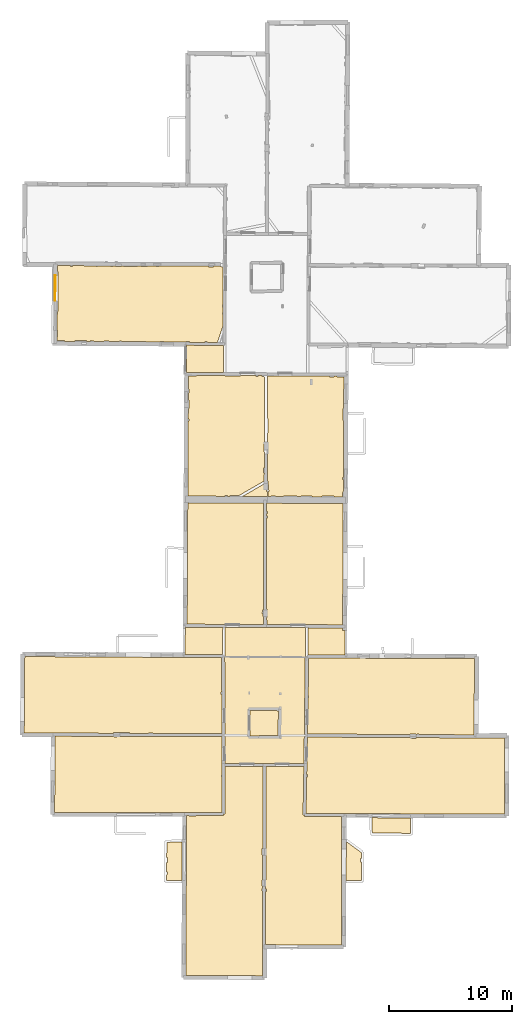
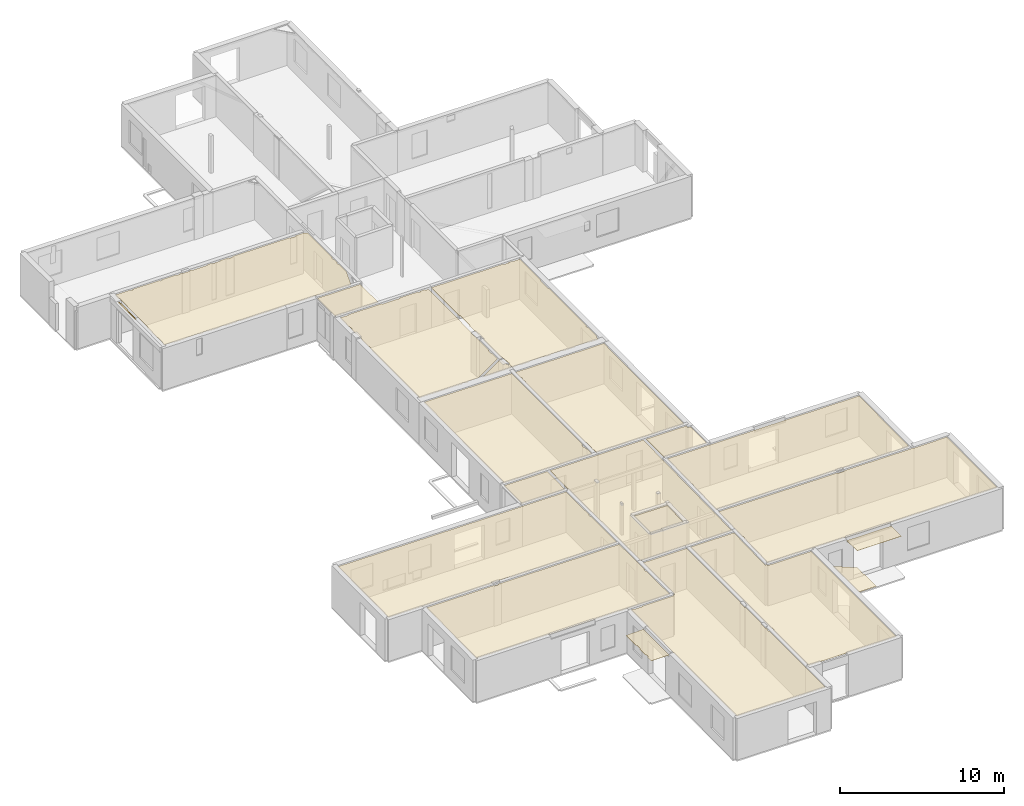
# One storey, part 14 of 17: 21 coverings.
"""IFC2X3 building model written with IfcOpenShell, lengths in metres."""

from ifc_helpers import new_model, entity, si_unit, converted_unit, derived_unit, direction, frame, origin, origin_with_axes, place, context, subcontext, project, spatial, polyline, outline, extrude, material, layer, layer_set, layer_usage, type_object, element, save


model = new_model("IFC2X3")

# Units and contexts
model_context = context("Model", 3, precision=1e-05, world=origin(), true_north=direction((0.0, 1.0)))
body_context = subcontext(model_context, "Body", "Model", "MODEL_VIEW")
ifc_project = project(units=[si_unit("LENGTHUNIT", "METRE"), si_unit("AREAUNIT", "SQUARE_METRE"), si_unit("VOLUMEUNIT", "CUBIC_METRE"), converted_unit("PLANEANGLEUNIT", "DEGREE", entity("IfcRatioMeasure", 0.0174532925199433), si_unit("PLANEANGLEUNIT", "RADIAN"), dimensions=[0, 0, 0, 0, 0, 0, 0]), si_unit("MASSUNIT", "GRAM", prefix="KILO"), derived_unit("MASSDENSITYUNIT", [(si_unit("MASSUNIT", "GRAM", prefix="KILO"), 1), (si_unit("LENGTHUNIT", "METRE"), -3)]), derived_unit("MOMENTOFINERTIAUNIT", [(si_unit("LENGTHUNIT", "METRE"), 4)]), si_unit("TIMEUNIT", "SECOND"), si_unit("FREQUENCYUNIT", "HERTZ"), si_unit("THERMODYNAMICTEMPERATUREUNIT", "DEGREE_CELSIUS"), derived_unit("THERMALTRANSMITTANCEUNIT", [(si_unit("MASSUNIT", "GRAM", prefix="KILO"), 1), (si_unit("THERMODYNAMICTEMPERATUREUNIT", "KELVIN"), -1), (si_unit("TIMEUNIT", "SECOND"), -3)]), derived_unit("VOLUMETRICFLOWRATEUNIT", [(si_unit("LENGTHUNIT", "METRE"), 3), (si_unit("TIMEUNIT", "SECOND"), -1)]), si_unit("ELECTRICCURRENTUNIT", "AMPERE"), si_unit("ELECTRICVOLTAGEUNIT", "VOLT"), si_unit("POWERUNIT", "WATT"), si_unit("FORCEUNIT", "NEWTON", prefix="KILO"), si_unit("ILLUMINANCEUNIT", "LUX"), si_unit("LUMINOUSFLUXUNIT", "LUMEN"), si_unit("LUMINOUSINTENSITYUNIT", "CANDELA"), derived_unit("USERDEFINED", [(si_unit("MASSUNIT", "GRAM", prefix="KILO"), -1), (si_unit("LENGTHUNIT", "METRE"), -2), (si_unit("TIMEUNIT", "SECOND"), 3), (si_unit("LUMINOUSFLUXUNIT", "LUMEN"), 1)]), derived_unit("LINEARVELOCITYUNIT", [(si_unit("LENGTHUNIT", "METRE"), 1), (si_unit("TIMEUNIT", "SECOND"), -1)]), si_unit("PRESSUREUNIT", "PASCAL"), derived_unit("USERDEFINED", [(si_unit("LENGTHUNIT", "METRE"), -2), (si_unit("MASSUNIT", "GRAM", prefix="KILO"), 1), (si_unit("TIMEUNIT", "SECOND"), -2)]), derived_unit("LINEARFORCEUNIT", [(si_unit("MASSUNIT", "GRAM", prefix="KILO"), 1), (si_unit("LENGTHUNIT", "METRE"), 1), (si_unit("TIMEUNIT", "SECOND"), -2), (si_unit("LENGTHUNIT", "METRE"), -1)]), derived_unit("PLANARFORCEUNIT", [(si_unit("MASSUNIT", "GRAM", prefix="KILO"), 1), (si_unit("LENGTHUNIT", "METRE"), 1), (si_unit("TIMEUNIT", "SECOND"), -2), (si_unit("LENGTHUNIT", "METRE"), -2)])], contexts=[model_context])

# Site, building, storey
placement = place(None, origin())
site = spatial("IfcSite", under=ifc_project, at=placement, CompositionType="ELEMENT")
building = spatial("IfcBuilding", under=site, at=placement, CompositionType="ELEMENT")
storey_placement = place(placement, frame((0.0, 0.0, 12.0782108306885)))
storey = spatial("IfcBuildingStorey", under=building, at=storey_placement, Name="Level 5", CompositionType="ELEMENT", Elevation=12.0782108306885)

# Coverings
ifc_material = material(Name="Covering default")
ifc_layer_1 = layer(ifc_material, 0.02)
ifc_layer_set_1 = layer_set([ifc_layer_1], Name="Covering : 20mm")
ifc_layer_usage_1 = layer_usage(ifc_layer_set_1, "AXIS3", "POSITIVE", 0.0)
covering_type_1 = type_object("IfcCoveringType", Name="Covering : 20mm", PredefinedType="CEILING")
covering_1_placement = place(placement, frame((0.0, 0.0, 15.0685014724731)))
element("IfcCovering", 1, at=covering_1_placement, inside=storey, type_object=covering_type_1, material=ifc_layer_usage_1, Name="Covering : 20mm", ObjectType="Covering : 20mm", PredefinedType="CEILING", context=body_context, shape_type="SweptSolid", body=[
    extrude(outline(polyline([(-0.138596534729004, 12.9248495101929), (0.0726919174194336, 12.9247789382935), (0.0727081298828125, 12.8729972839355), (0.622707366943359, 12.8731727600098), (0.62269115447998, 12.924596786499), (2.86712169647217, 12.9238567352295), (2.86716175079346, 13.0438566207886), (2.99216175079346, 13.0441961288452), (2.98171901702881, 16.8851890563965), (6.06517505645752, 16.8840351104736), (6.04646015167236, 10.2290496826172), (5.98586940765381, 10.2296514511108), (5.98055553436279, 9.69467830657959), (6.04495525360107, 9.6940393447876), (6.03923511505127, 7.65957021713257), (5.97211170196533, 7.65948629379272), (5.972731590271, 7.16448640823364), (6.03784275054932, 7.1645679473877), (6.03728199005127, 6.96490812301636), (5.98459911346436, 6.96489143371582), (5.98466014862061, 6.77488899230957), (6.03674602508545, 6.77490568161011), (6.02285861968994, 1.8364577293396), (6.02210712432861, -0.111004292964935), (-0.206916809082031, -0.0680429339408875), (-0.138596534729004, 12.9248495101929)])), origin_with_axes(), (0.0, 0.0, 1.0), 0.02),
])
ifc_layer_2 = layer(ifc_material, 0.02)
ifc_layer_set_2 = layer_set([ifc_layer_2], Name="Covering : 20mm")
ifc_layer_usage_2 = layer_usage(ifc_layer_set_2, "AXIS3", "POSITIVE", 0.0)
covering_type_2 = type_object("IfcCoveringType", Name="Covering : 20mm", PredefinedType="CEILING")
covering_2_placement = place(placement, frame((0.0, 0.0, 15.0685014724731)))
element("IfcCovering", 2, at=covering_2_placement, inside=storey, type_object=covering_type_2, material=ifc_layer_usage_2, Name="Covering : 20mm", ObjectType="Covering : 20mm", PredefinedType="CEILING", context=body_context, shape_type="SweptSolid", body=[
    extrude(outline(polyline([(6.28663539886475, 6.73498678207397), (6.3446741104126, 6.73500442504883), (6.34460735321045, 6.94500350952148), (6.28722476959229, 6.94498538970947), (6.31517505645752, 16.8839416503906), (9.38714504241943, 16.882791519165), (9.31783199310303, 12.9620161056519), (9.43781566619873, 12.9598951339722), (9.43731784820557, 12.8348960876465), (12.4557752609253, 12.8228902816772), (12.4336462020874, 2.39072966575623), (8.92137813568115, 2.4057776927948), (6.2744836807251, 2.41390013694763), (6.28663539886475, 6.73498678207397)])), origin_with_axes(), (0.0, 0.0, 1.0), 0.02),
])
ifc_layer_3 = layer(ifc_material, 0.02)
ifc_layer_set_3 = layer_set([ifc_layer_3], Name="Covering : 20mm")
ifc_layer_usage_3 = layer_usage(ifc_layer_set_3, "AXIS3", "POSITIVE", 0.0)
covering_type_3 = type_object("IfcCoveringType", Name="Covering : 20mm", PredefinedType="CEILING")
covering_3_placement = place(placement, frame((0.0, 0.0, 15.0685014724731)))
element("IfcCovering", 3, at=covering_3_placement, inside=storey, type_object=covering_type_3, material=ifc_layer_usage_3, Name="Covering : 20mm", ObjectType="Covering : 20mm", PredefinedType="CEILING", context=body_context, shape_type="SweptSolid", body=[
    extrude(outline(polyline([(-1.76703453063965, 8.06430816650391), (-1.71575260162354, 8.06242561340332), (-1.70583915710449, 8.33242607116699), (-1.76493072509766, 8.33459568023682), (-1.75909996032715, 9.08370208740234), (-1.70607948303223, 9.08242607116699), (-1.69620990753174, 9.492431640625), (-1.75590705871582, 9.49386882781982), (-1.74627876281738, 10.7308292388916), (-0.49996280670166, 10.7643165588379), (-0.516502380371094, 7.61877489089966), (-1.7704610824585, 7.62411737442017), (-1.76703453063965, 8.06430816650391)])), origin_with_axes(), (0.0, 0.0, 1.0), 0.02),
])
ifc_layer_4 = layer(ifc_material, 0.02)
ifc_layer_set_4 = layer_set([ifc_layer_4], Name="Covering : 20mm")
ifc_layer_usage_4 = layer_usage(ifc_layer_set_4, "AXIS3", "POSITIVE", 0.0)
covering_type_4 = type_object("IfcCoveringType", Name="Covering : 20mm", PredefinedType="CEILING")
covering_4_placement = place(placement, frame((0.0, 0.0, 15.0685014724731)))
element("IfcCovering", 4, at=covering_4_placement, inside=storey, type_object=covering_type_4, material=ifc_layer_usage_4, Name="Covering : 20mm", ObjectType="Covering : 20mm", PredefinedType="CEILING", context=body_context, shape_type="SweptSolid", body=[
    extrude(outline(polyline([(12.8314752578735, 10.7952356338501), (14.0552072525024, 9.89634132385254), (14.0553102493286, 9.43747806549072), (14.003809928894, 9.43746185302734), (14.0039052963257, 9.13745880126953), (14.0553770065308, 9.13747501373291), (14.0532636642456, 7.63131189346313), (12.8247690200806, 7.63414335250854), (12.8314752578735, 10.7952356338501)])), origin_with_axes(), (0.0, 0.0, 1.0), 0.02),
])
ifc_layer_5 = layer(ifc_material, 0.02)
ifc_layer_set_5 = layer_set([ifc_layer_5], Name="Covering : 20mm")
ifc_layer_usage_5 = layer_usage(ifc_layer_set_5, "AXIS3", "POSITIVE", 0.0)
covering_type_5 = type_object("IfcCoveringType", Name="Covering : 20mm", PredefinedType="CEILING")
covering_5_placement = place(placement, frame((0.0, 0.0, 15.0685014724731)))
element("IfcCovering", 5, at=covering_5_placement, inside=storey, type_object=covering_type_5, material=ifc_layer_usage_5, Name="Covering : 20mm", ObjectType="Covering : 20mm", PredefinedType="CEILING", context=body_context, shape_type="SweptSolid", body=[
    extrude(outline(polyline([(14.9444761276245, 11.4771718978882), (18.0323600769043, 11.4665374755859), (18.045768737793, 12.7178363800049), (14.911395072937, 12.7298250198364), (14.9444761276245, 11.4771718978882)])), origin_with_axes(), (0.0, 0.0, 1.0), 0.02),
])
ifc_layer_6 = layer(ifc_material, 0.02)
ifc_layer_set_6 = layer_set([ifc_layer_6], Name="Covering : 20mm")
ifc_layer_usage_6 = layer_usage(ifc_layer_set_6, "AXIS3", "POSITIVE", 0.0)
covering_type_6 = type_object("IfcCoveringType", Name="Covering : 20mm", PredefinedType="CEILING")
covering_6_placement = place(placement, frame((0.0, 0.0, 15.0685014724731)))
element("IfcCovering", 6, at=covering_6_placement, inside=storey, type_object=covering_type_6, material=ifc_layer_usage_6, Name="Covering : 20mm", ObjectType="Covering : 20mm", PredefinedType="CEILING", context=body_context, shape_type="SweptSolid", body=[
    extrude(outline(polyline([(9.61256885528564, 16.0560550689697), (9.67169094085693, 16.0560741424561), (9.67162609100342, 16.2560710906982), (9.61610317230225, 16.2560539245605), (9.63156414031982, 17.1305866241455), (9.63156414031982, 17.1305866241455), (9.66959476470947, 19.2818756103516), (18.0216979980469, 19.2391090393066), (18.0206871032715, 19.1887435913086), (18.5106925964355, 19.1789035797119), (18.5118522644043, 19.2365989685059), (23.3787498474121, 19.2116775512695), (23.3788833618164, 19.1865901947021), (25.6989898681641, 19.1988983154297), (25.6770668029785, 13.018651008606), (9.56003475189209, 13.0844097137451), (9.61256885528564, 16.0560550689697)])), origin_with_axes(), (0.0, 0.0, 1.0), 0.02),
])
ifc_layer_7 = layer(ifc_material, 0.02)
ifc_layer_set_7 = layer_set([ifc_layer_7], Name="Covering : 20mm")
ifc_layer_usage_7 = layer_usage(ifc_layer_set_7, "AXIS3", "POSITIVE", 0.0)
covering_type_7 = type_object("IfcCoveringType", Name="Covering : 20mm", PredefinedType="CEILING")
covering_7_placement = place(placement, frame((0.0, 0.0, 15.0685014724731)))
element("IfcCovering", 7, at=covering_7_placement, inside=storey, type_object=covering_type_7, material=ifc_layer_usage_7, Name="Covering : 20mm", ObjectType="Covering : 20mm", PredefinedType="CEILING", context=body_context, shape_type="SweptSolid", body=[
    extrude(outline(polyline([(-10.8123950958252, 19.3526554107666), (-6.03936290740967, 19.3384819030762), (-6.0393443107605, 19.2810440063477), (-5.79934453964233, 19.281120300293), (-5.79936265945435, 19.3377704620361), (2.72511959075928, 19.3124580383301), (2.73104000091553, 17.134895324707), (2.73354434967041, 16.2138538360596), (2.68163967132568, 16.2138366699219), (2.6816930770874, 16.0438346862793), (2.73400592803955, 16.043851852417), (2.74183368682861, 13.1638984680176), (-10.8625917434692, 13.1704225540161), (-10.8123950958252, 19.3526554107666)])), origin_with_axes(), (0.0, 0.0, 1.0), 0.02),
])
ifc_layer_8 = layer(ifc_material, 0.02)
ifc_layer_set_8 = layer_set([ifc_layer_8], Name="Covering : 20mm")
ifc_layer_usage_8 = layer_usage(ifc_layer_set_8, "AXIS3", "POSITIVE", 0.0)
covering_type_8 = type_object("IfcCoveringType", Name="Covering : 20mm", PredefinedType="CEILING")
covering_8_placement = place(placement, frame((0.0, 0.0, 15.0685014724731)))
element("IfcCovering", 8, at=covering_8_placement, inside=storey, type_object=covering_type_8, material=ifc_layer_usage_8, Name="Covering : 20mm", ObjectType="Covering : 20mm", PredefinedType="CEILING", context=body_context, shape_type="SweptSolid", body=[
    extrude(outline(polyline([(2.98104000091553, 17.1351909637451), (6.06557369232178, 17.1340351104736), (6.06557369232178, 17.1340351104736), (9.39156436920166, 17.1327896118164), (9.52781391143799, 28.1637325286865), (2.9985990524292, 28.1903381347656), (2.96671772003174, 25.8740901947021), (2.95728015899658, 25.8742198944092), (2.98104000091553, 17.1351909637451)])), origin_with_axes(), (0.0, 0.0, 1.0), 0.02),
])
ifc_layer_9 = layer(ifc_material, 0.02)
ifc_layer_set_9 = layer_set([ifc_layer_9], Name="Covering : 20mm")
ifc_layer_usage_9 = layer_usage(ifc_layer_set_9, "AXIS3", "POSITIVE", 0.0)
covering_type_9 = type_object("IfcCoveringType", Name="Covering : 20mm", PredefinedType="CEILING")
covering_9_placement = place(placement, frame((0.0, 0.0, 15.0685014724731)))
element("IfcCovering", 9, at=covering_9_placement, inside=storey, type_object=covering_type_9, material=ifc_layer_usage_9, Name="Covering : 20mm", ObjectType="Covering : 20mm", PredefinedType="CEILING", context=body_context, shape_type="SweptSolid", body=[
    extrude(outline(polyline([(4.99934101104736, 21.4521389007568), (7.3146505355835, 21.4184799194336), (7.28621959686279, 19.4041957855225), (5.72200489044189, 19.4202365875244), (5.72152805328369, 19.3737831115723), (4.99195575714111, 19.3829326629639), (4.99934101104736, 21.4521389007568)])), origin_with_axes(), (0.0, 0.0, 1.0), 0.02),
])
ifc_layer_10 = layer(ifc_material, 0.02)
ifc_layer_set_10 = layer_set([ifc_layer_10], Name="Covering : 20mm")
ifc_layer_usage_10 = layer_usage(ifc_layer_set_10, "AXIS3", "POSITIVE", 0.0)
covering_type_10 = type_object("IfcCoveringType", Name="Covering : 20mm", PredefinedType="CEILING")
covering_10_placement = place(placement, frame((0.0, 0.0, 15.0685014724731)))
element("IfcCovering", 10, at=covering_10_placement, inside=storey, type_object=covering_type_10, material=ifc_layer_usage_10, Name="Covering : 20mm", ObjectType="Covering : 20mm", PredefinedType="CEILING", context=body_context, shape_type="SweptSolid", body=[
    extrude(outline(polyline([(9.72606182098389, 22.4760913848877), (9.77963352203369, 22.4761085510254), (9.77957630157471, 22.6561088562012), (9.72924327850342, 22.6560935974121), (9.78309726715088, 25.7024211883545), (23.2546691894531, 25.651554107666), (23.1935653686523, 19.4626293182373), (18.7505950927734, 19.4853801727295), (18.7505760192871, 19.5389804840088), (18.590576171875, 19.5389289855957), (18.5905914306641, 19.486198425293), (18.5033645629883, 19.486644744873), (18.5035400390625, 19.5310878753662), (18.013542175293, 19.5330390930176), (18.0133666992188, 19.4891548156738), (9.6740140914917, 19.5318565368652), (9.72606182098389, 22.4760913848877)])), origin_with_axes(), (0.0, 0.0, 1.0), 0.02),
])
ifc_layer_11 = layer(ifc_material, 0.02)
ifc_layer_set_11 = layer_set([ifc_layer_11], Name="Covering : 20mm")
ifc_layer_usage_11 = layer_usage(ifc_layer_set_11, "AXIS3", "POSITIVE", 0.0)
covering_type_11 = type_object("IfcCoveringType", Name="Covering : 20mm", PredefinedType="CEILING")
covering_11_placement = place(placement, frame((0.0, 0.0, 15.0685014724731)))
element("IfcCovering", 11, at=covering_11_placement, inside=storey, type_object=covering_type_11, material=ifc_layer_usage_11, Name="Covering : 20mm", ObjectType="Covering : 20mm", PredefinedType="CEILING", context=body_context, shape_type="SweptSolid", body=[
    extrude(outline(polyline([(-13.2874841690063, 25.8209762573242), (-0.354736328125, 25.7471199035645), (-0.354683876037598, 25.7563724517822), (2.70761394500732, 25.7507610321045), (2.71524715423584, 22.9438457489014), (2.65948390960693, 22.9438285827637), (2.65954494476318, 22.7538261413574), (2.7157621383667, 22.7538452148438), (2.724440574646, 19.5624599456787), (-2.86944007873535, 19.5790710449219), (-2.86945629119873, 19.6320571899414), (-3.21945667266846, 19.6319446563721), (-3.21944046020508, 19.5801105499268), (-4.77087688446045, 19.584716796875), (-4.76945972442627, 19.6414470672607), (-5.55946445465088, 19.6611957550049), (-5.55973815917969, 19.6502437591553), (-6.07396411895752, 19.6611499786377), (-6.07550287246704, 19.5885906219482), (-13.3329524993896, 19.6114082336426), (-13.2874841690063, 25.8209762573242)])), origin_with_axes(), (0.0, 0.0, 1.0), 0.02),
])
ifc_layer_12 = layer(ifc_material, 0.02)
ifc_layer_set_12 = layer_set([ifc_layer_12], Name="Covering : 20mm")
ifc_layer_usage_12 = layer_usage(ifc_layer_set_12, "AXIS3", "POSITIVE", 0.0)
covering_type_12 = type_object("IfcCoveringType", Name="Covering : 20mm", PredefinedType="CEILING")
covering_12_placement = place(placement, frame((0.0, 0.0, 15.0685014724731)))
element("IfcCovering", 12, at=covering_12_placement, inside=storey, type_object=covering_type_12, material=ifc_layer_usage_12, Name="Covering : 20mm", ObjectType="Covering : 20mm", PredefinedType="CEILING", context=body_context, shape_type="SweptSolid", body=[
    extrude(outline(polyline([(9.72781276702881, 28.1629161834717), (12.5310297012329, 28.1514930725098), (12.5300359725952, 27.9473705291748), (12.730034828186, 27.9463958740234), (12.7202615737915, 25.9402351379395), (9.72852039337158, 25.9526500701904), (9.72781276702881, 28.1629161834717)])), origin_with_axes(), (0.0, 0.0, 1.0), 0.02),
])
ifc_layer_13 = layer(ifc_material, 0.02)
ifc_layer_set_13 = layer_set([ifc_layer_13], Name="Covering : 20mm")
ifc_layer_usage_13 = layer_usage(ifc_layer_set_13, "AXIS3", "POSITIVE", 0.0)
covering_type_13 = type_object("IfcCoveringType", Name="Covering : 20mm", PredefinedType="CEILING")
covering_13_placement = place(placement, frame((0.0, 0.0, 15.0685014724731)))
element("IfcCovering", 13, at=covering_13_placement, inside=storey, type_object=covering_type_13, material=ifc_layer_usage_13, Name="Covering : 20mm", ObjectType="Covering : 20mm", PredefinedType="CEILING", context=body_context, shape_type="SweptSolid", body=[
    extrude(outline(polyline([(-0.246853828430176, 28.2035636901855), (2.79859256744385, 28.1911544799805), (2.76843929290771, 26.0006504058838), (-0.258289337158203, 26.006196975708), (-0.246853828430176, 28.2035636901855)])), origin_with_axes(), (0.0, 0.0, 1.0), 0.02),
])
ifc_layer_14 = layer(ifc_material, 0.02)
ifc_layer_set_14 = layer_set([ifc_layer_14], Name="Covering : 20mm")
ifc_layer_usage_14 = layer_usage(ifc_layer_set_14, "AXIS3", "POSITIVE", 0.0)
covering_type_14 = type_object("IfcCoveringType", Name="Covering : 20mm", PredefinedType="CEILING")
covering_14_placement = place(placement, frame((0.0, 0.0, 15.0685014724731)))
element("IfcCovering", 14, at=covering_14_placement, inside=storey, type_object=covering_type_14, material=ifc_layer_usage_14, Name="Covering : 20mm", ObjectType="Covering : 20mm", PredefinedType="CEILING", context=body_context, shape_type="SweptSolid", body=[
    extrude(outline(polyline([(6.33995532989502, 28.9850044250488), (6.39755153656006, 28.9850234985352), (6.39732646942139, 29.6850242614746), (6.3419771194458, 29.6850070953369), (6.36331462860107, 37.0750160217285), (6.41496181488037, 37.0750312805176), (6.41491222381592, 37.2250328063965), (6.36374759674072, 37.2250175476074), (6.36436367034912, 37.4381713867188), (6.41484546661377, 37.4350318908691), (6.42479419708252, 37.5950355529785), (6.36482715606689, 37.5987663269043), (6.36680316925049, 38.2831192016602), (6.41302013397217, 38.2828712463379), (12.5802221298218, 38.249870300293), (12.5322484970093, 28.4014911651611), (6.40975093841553, 28.426441192627), (6.39761829376221, 28.7750244140625), (6.33934307098389, 28.7729969024658), (6.33995532989502, 28.9850044250488)])), origin_with_axes(), (0.0, 0.0, 1.0), 0.02),
])
ifc_layer_15 = layer(ifc_material, 0.02)
ifc_layer_set_15 = layer_set([ifc_layer_15], Name="Covering : 20mm")
ifc_layer_usage_15 = layer_usage(ifc_layer_set_15, "AXIS3", "POSITIVE", 0.0)
covering_type_15 = type_object("IfcCoveringType", Name="Covering : 20mm", PredefinedType="CEILING")
covering_15_placement = place(placement, frame((0.0, 0.0, 15.0685014724731)))
element("IfcCovering", 15, at=covering_15_placement, inside=storey, type_object=covering_type_15, material=ifc_layer_usage_15, Name="Covering : 20mm", ObjectType="Covering : 20mm", PredefinedType="CEILING", context=body_context, shape_type="SweptSolid", body=[
    extrude(outline(polyline([(-0.044215202331543, 38.3174247741699), (6.11680507659912, 38.2844581604004), (6.09177875518799, 29.6174221038818), (6.03734493255615, 29.6249122619629), (5.99743938446045, 29.3348979949951), (6.05424785614014, 29.3270816802979), (6.05777645111084, 29.080394744873), (6.09022998809814, 29.0808582305908), (6.08834362030029, 28.4277496337891), (-0.0955533981323242, 28.4529495239258), (-0.044215202331543, 38.3174247741699)])), origin_with_axes(), (0.0, 0.0, 1.0), 0.02),
])
ifc_layer_16 = layer(ifc_material, 0.02)
ifc_layer_set_16 = layer_set([ifc_layer_16], Name="Covering : 20mm")
ifc_layer_usage_16 = layer_usage(ifc_layer_set_16, "AXIS3", "POSITIVE", 0.0)
covering_type_16 = type_object("IfcCoveringType", Name="Covering : 20mm", PredefinedType="CEILING")
covering_16_placement = place(placement, frame((0.0, 0.0, 15.0685014724731)))
element("IfcCovering", 16, at=covering_16_placement, inside=storey, type_object=covering_type_16, material=ifc_layer_usage_16, Name="Covering : 20mm", ObjectType="Covering : 20mm", PredefinedType="CEILING", context=body_context, shape_type="SweptSolid", body=[
    extrude(outline(polyline([(6.42223072052002, 42.283763885498), (6.46329212188721, 42.2850456237793), (6.42821025848389, 43.9750328063965), (6.48275279998779, 43.9750518798828), (6.48236751556396, 45.1750526428223), (6.43216991424561, 45.1750373840332), (6.44354724884033, 48.6230926513672), (11.4512701034546, 48.606559753418), (11.4512891769409, 48.5466461181641), (11.8512868881226, 48.5467720031738), (11.8512697219849, 48.6041221618652), (12.0912714004517, 48.6026573181152), (12.0912885665894, 48.5468482971191), (12.6303853988647, 48.5470199584961), (12.6178178787231, 45.9670181274414), (12.5621137619019, 45.9669990539551), (12.5624284744263, 44.9869995117188), (12.6130437850952, 44.9870147705078), (12.590537071228, 40.3670082092285), (12.5339078903198, 40.3669891357422), (12.5339574813843, 40.2069892883301), (12.5897569656372, 40.2070083618164), (12.5845346450806, 39.1351432800293), (12.5343008041382, 39.1369895935059), (12.5215673446655, 38.7901916503906), (11.8138608932495, 38.7939796447754), (11.8143949508667, 38.8467597961426), (10.8543920516968, 38.8564529418945), (10.8538122177124, 38.7991180419922), (10.0538129806519, 38.8033981323242), (10.054388999939, 38.8561973571777), (9.16438770294189, 38.865909576416), (9.16375827789307, 38.808162689209), (8.84389591217041, 38.809871673584), (8.84438610076904, 38.8658103942871), (7.74438381195068, 38.8754539489746), (7.74386119842529, 38.8157577514648), (7.07440280914307, 38.8193397521973), (7.07438564300537, 38.8752403259277), (6.70438289642334, 38.8751220703125), (6.70440006256104, 38.8213195800781), (6.48521900177002, 38.8224945068359), (6.48638439178467, 39.2397956848145), (6.544264793396, 39.2450752258301), (6.46674823760986, 40.0947494506836), (6.4159517288208, 40.0901145935059), (6.42223072052002, 42.283763885498)])), origin_with_axes(), (0.0, 0.0, 1.0), 0.02),
])
ifc_layer_17 = layer(ifc_material, 0.02)
ifc_layer_set_17 = layer_set([ifc_layer_17], Name="Covering : 20mm")
ifc_layer_usage_17 = layer_usage(ifc_layer_set_17, "AXIS3", "POSITIVE", 0.0)
covering_type_17 = type_object("IfcCoveringType", Name="Covering : 20mm", PredefinedType="CEILING")
covering_17_placement = place(placement, frame((0.0, 0.0, 15.0685014724731)))
element("IfcCovering", 17, at=covering_17_placement, inside=storey, type_object=covering_type_17, material=ifc_layer_usage_17, Name="Covering : 20mm", ObjectType="Covering : 20mm", PredefinedType="CEILING", context=body_context, shape_type="SweptSolid", body=[
    extrude(outline(polyline([(4.39929485321045, 38.8336563110352), (6.28178119659424, 39.9208679199219), (6.34509181976318, 39.2269058227539), (6.41636753082275, 39.2334060668945), (6.4152193069458, 38.822868347168), (4.39929485321045, 38.8336563110352)])), origin_with_axes(), (0.0, 0.0, 1.0), 0.02),
])
ifc_layer_18 = layer(ifc_material, 0.02)
ifc_layer_set_18 = layer_set([ifc_layer_18], Name="Covering : 20mm")
ifc_layer_usage_18 = layer_usage(ifc_layer_set_18, "AXIS3", "POSITIVE", 0.0)
covering_type_18 = type_object("IfcCoveringType", Name="Covering : 20mm", PredefinedType="CEILING")
covering_18_placement = place(placement, frame((0.0, 0.0, 15.0685014724731)))
element("IfcCovering", 18, at=covering_18_placement, inside=storey, type_object=covering_type_18, material=ifc_layer_usage_18, Name="Covering : 20mm", ObjectType="Covering : 20mm", PredefinedType="CEILING", context=body_context, shape_type="SweptSolid", body=[
    extrude(outline(polyline([(-0.00973415374755859, 44.9429779052734), (0.0424404144287109, 44.9429931640625), (0.0423803329467773, 45.1329917907715), (-0.00874614715576172, 45.1329765319824), (-0.00442600250244141, 45.9629783630371), (0.0521144866943359, 45.9629974365234), (0.0518932342529297, 46.6529922485352), (-0.000835418701171875, 46.6529769897461), (0.00207901000976562, 47.2129783630371), (0.0617141723632812, 47.2129974365234), (0.0616025924682617, 47.5629997253418), (0.00390052795410156, 47.5629806518555), (0.00943279266357422, 48.6260833740234), (0.651266098022461, 48.6131858825684), (0.652456283569336, 48.6724281311035), (2.97208881378174, 48.6582794189453), (2.97169399261475, 48.6033248901367), (4.22127246856689, 48.5943298339844), (4.22167873382568, 48.6506576538086), (5.4912576675415, 48.6429138183594), (5.49127674102783, 48.5847358703613), (5.66127681732178, 48.584789276123), (5.66125965118408, 48.6418762207031), (5.99156284332275, 48.6398620605469), (5.981276512146, 48.5848922729492), (6.1932897567749, 48.5452156066895), (6.1758394241333, 43.256721496582), (6.132981300354, 43.254940032959), (6.17230129241943, 42.3088188171387), (6.16891193389893, 41.1249504089355), (6.11366367340088, 41.1249313354492), (6.11378383636475, 40.7449340820312), (6.16782474517822, 40.7449531555176), (6.16593647003174, 40.0849189758301), (4.10437297821045, 38.894287109375), (3.37437725067139, 38.8940582275391), (3.37439441680908, 38.8391418457031), (3.16439533233643, 38.8402633666992), (3.16437816619873, 38.8939895629883), (2.97437763214111, 38.893928527832), (2.97439479827881, 38.8412818908691), (-0.0414056777954102, 38.857421875), (-0.00973415374755859, 44.9429779052734)])), origin_with_axes(), (0.0, 0.0, 1.0), 0.02),
])
ifc_layer_19 = layer(ifc_material, 0.02)
ifc_layer_set_19 = layer_set([ifc_layer_19], Name="Covering : 20mm")
ifc_layer_usage_19 = layer_usage(ifc_layer_set_19, "AXIS3", "POSITIVE", 0.0)
covering_type_19 = type_object("IfcCoveringType", Name="Covering : 20mm", PredefinedType="CEILING")
covering_19_placement = place(placement, frame((0.0, 0.0, 15.0685014724731)))
element("IfcCovering", 19, at=covering_19_placement, inside=storey, type_object=covering_type_19, material=ifc_layer_usage_19, Name="Covering : 20mm", ObjectType="Covering : 20mm", PredefinedType="CEILING", context=body_context, shape_type="SweptSolid", body=[
    extrude(outline(polyline([(-0.157381057739258, 49.2385368347168), (-0.162118911743164, 49.2385597229004), (-0.16234016418457, 51.1169052124023), (2.86043643951416, 51.0911521911621), (2.87143230438232, 48.8988990783691), (-0.159052848815918, 48.9173812866211), (-0.157381057739258, 49.2385368347168)])), origin_with_axes(), (0.0, 0.0, 1.0), 0.02),
])
ifc_layer_20 = layer(ifc_material, 0.02)
ifc_layer_set_20 = layer_set([ifc_layer_20], Name="Covering : 20mm")
ifc_layer_usage_20 = layer_usage(ifc_layer_set_20, "AXIS3", "POSITIVE", 0.0)
covering_type_20 = type_object("IfcCoveringType", Name="Covering : 20mm", PredefinedType="CEILING")
covering_20_placement = place(placement, frame((0.0, 0.0, 15.0685014724731)))
element("IfcCovering", 20, at=covering_20_placement, inside=storey, type_object=covering_type_20, material=ifc_layer_usage_20, Name="Covering : 20mm", ObjectType="Covering : 20mm", PredefinedType="CEILING", context=body_context, shape_type="SweptSolid", body=[
    extrude(outline(polyline([(-10.6850872039795, 51.7795562744141), (-10.6297473907471, 51.7795753479004), (-10.6299285888672, 52.3495750427246), (-10.6802139282227, 52.3495597839355), (-10.6694345474243, 53.610237121582), (-10.6103324890137, 53.6095809936523), (-10.5714550018311, 57.1095962524414), (-10.6299676895142, 57.1102447509766), (-10.6158475875854, 57.5770530700684), (-9.58160209655762, 57.5734748840332), (-9.58158493041992, 57.5199127197266), (-9.41158676147461, 57.5199661254883), (-9.4116039276123, 57.5728874206543), (-7.51159954071045, 57.5663108825684), (-7.51158285140991, 57.5105743408203), (-7.36158132553101, 57.5106201171875), (-7.36159801483154, 57.5657920837402), (-6.34160137176514, 57.5622634887695), (-6.3415846824646, 57.5109481811523), (-6.11158323287964, 57.5110244750977), (-6.11159992218018, 57.561466217041), (-5.92619752883911, 57.5608253479004), (-5.92654085159302, 57.5032615661621), (-5.41154956817627, 57.500186920166), (-5.41119861602783, 57.5590438842773), (-5.26159954071045, 57.5585289001465), (-5.26158046722412, 57.5012969970703), (-4.13158130645752, 57.5016555786133), (-4.1315975189209, 57.5546188354492), (-3.85065174102783, 57.5536460876465), (-3.85158061981201, 57.5017471313477), (-3.3015775680542, 57.4919204711914), (-3.30050849914551, 57.5517425537109), (-2.6415958404541, 57.5494613647461), (-2.64157772064209, 57.4921340942383), (-2.40157794952393, 57.4922103881836), (-2.40159606933594, 57.5486335754395), (1.63965702056885, 57.5346488952637), (1.63842678070068, 57.4835052490234), (2.04842948913574, 57.4736366271973), (2.04986381530762, 57.5332298278809), (2.46796131134033, 57.5317840576172), (2.46809482574463, 57.5701293945312), (2.83334445953369, 57.4332962036133), (2.81682109832764, 54.403881072998), (2.75941181182861, 54.4038619995117), (2.75948238372803, 54.1838607788086), (2.8156213760376, 54.1838798522949), (2.81343936920166, 53.7838821411133), (2.75961017608643, 53.783863067627), (2.75966739654541, 53.6038627624512), (2.81245899200439, 53.6038780212402), (2.80739879608154, 52.6761741638184), (2.36095523834229, 51.3354148864746), (1.53738975524902, 51.3424301147461), (1.54037570953369, 51.3934707641602), (1.37037181854248, 51.4034156799316), (1.36688995361328, 51.3438835144043), (0.0967435836791992, 51.3547019958496), (0.100369453430176, 51.4130096435547), (-0.191158294677734, 51.4311370849609), (-0.194465637207031, 51.3779487609863), (-1.99170017242432, 51.3878555297852), (-1.99153518676758, 51.4178657531738), (-2.30652523040771, 51.4196014404297), (-2.30669021606445, 51.389591217041), (-5.42962837219238, 51.4068031311035), (-5.42964649200439, 51.4612426757812), (-5.60964679718018, 51.461181640625), (-5.60962867736816, 51.4077949523926), (-6.4496283531189, 51.412425994873), (-6.44964742660522, 51.4709167480469), (-6.83965063095093, 51.4707908630371), (-6.83963251113892, 51.4145774841309), (-7.66134786605835, 51.4191055297852), (-7.65965032577515, 51.4705276489258), (-7.95965337753296, 51.4804306030273), (-7.9616231918335, 51.4207611083984), (-8.25963592529297, 51.4224052429199), (-8.25965309143066, 51.4803314208984), (-9.20965385437012, 51.4800300598145), (-9.20963668823242, 51.4276390075684), (-10.0496387481689, 51.4322700500488), (-10.0496559143066, 51.4897613525391), (-10.6875667572021, 51.4895553588867), (-10.6850872039795, 51.7795562744141)])), origin_with_axes(), (0.0, 0.0, 1.0), 0.02),
])
ifc_layer_21 = layer(ifc_material, 0.02)
ifc_layer_set_21 = layer_set([ifc_layer_21], Name="Covering : 20mm")
ifc_layer_usage_21 = layer_usage(ifc_layer_set_21, "AXIS3", "POSITIVE", 0.0)
covering_type_21 = type_object("IfcCoveringType", Name="Covering : 20mm", PredefinedType="CEILING")
covering_21_placement = place(placement, frame((0.0, 0.0, 15.0685014724731)))
element("IfcCovering", 21, at=covering_21_placement, inside=storey, type_object=covering_type_21, material=ifc_layer_usage_21, Name="Covering : 20mm", ObjectType="Covering : 20mm", PredefinedType="CEILING", context=body_context, shape_type="SweptSolid", body=[
    extrude(outline(polyline([(-10.8421592712402, 56.801342010498), (-10.7749137878418, 56.7993087768555), (-10.7980365753174, 54.7176208496094), (-10.8599700927734, 54.7181510925293), (-10.8421592712402, 56.801342010498)])), origin_with_axes(), (0.0, 0.0, 1.0), 0.02),
])

save(model, "model.ifc")
